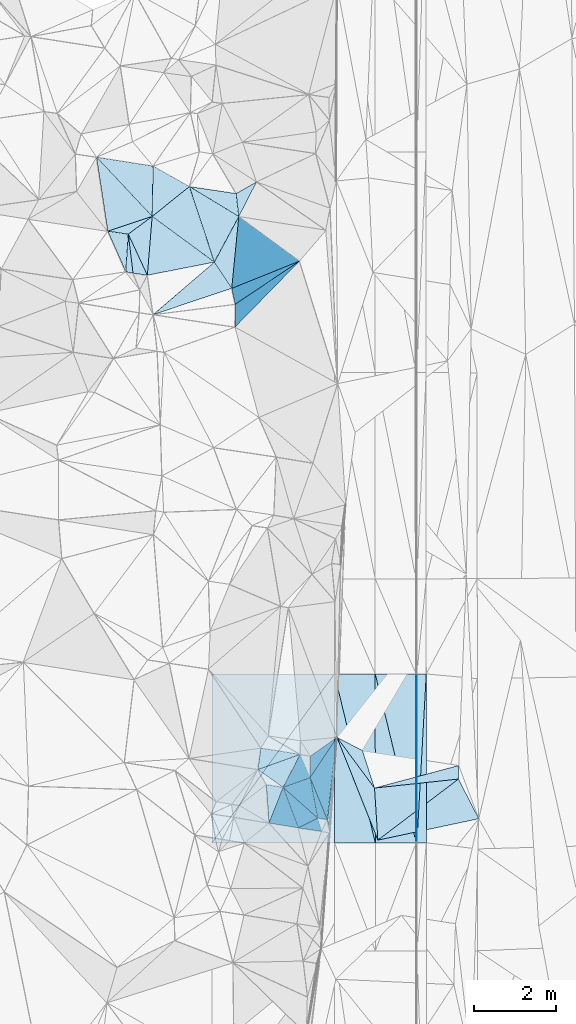
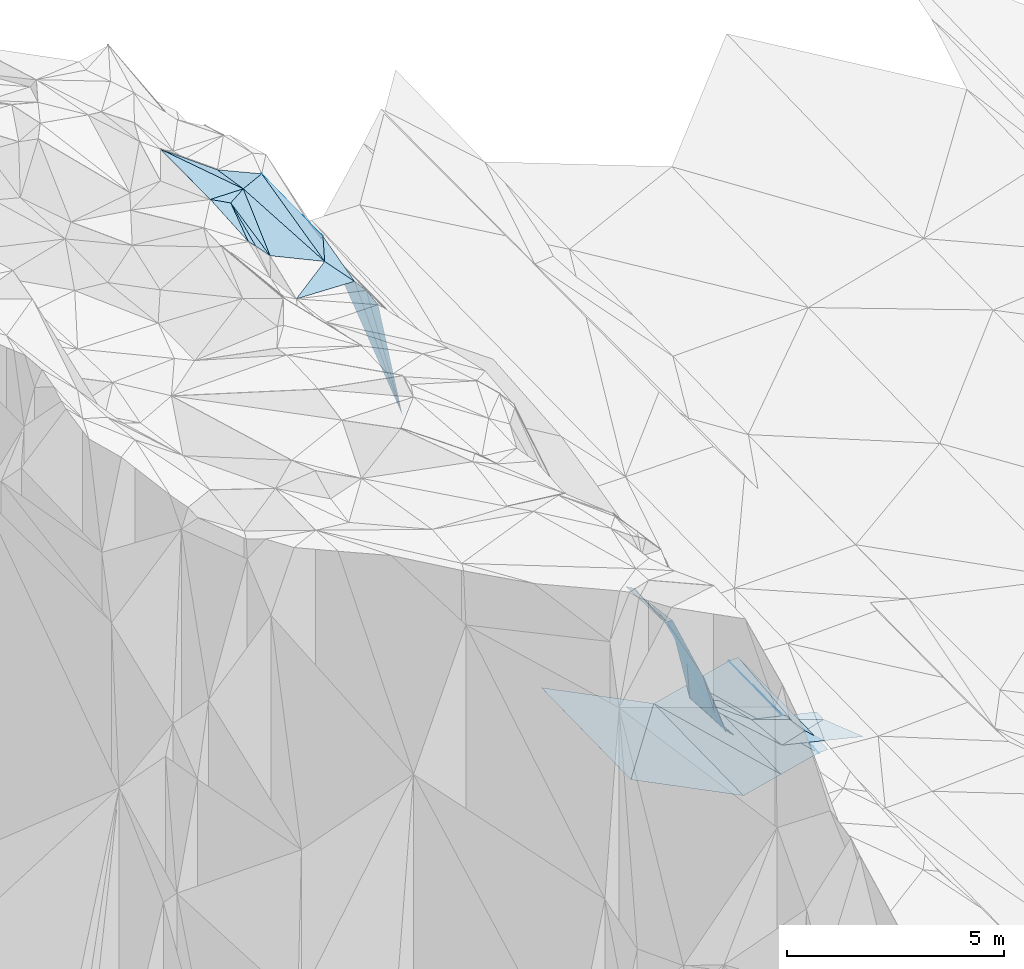
# One storey, part 137 of 275: 45 plates.
"""IFC2X3 building model written with IfcOpenShell, lengths in millimetres."""

from ifc_helpers import new_model, si_unit, frame, origin_with_axes, place, context, subcontext, project, spatial, polyline, outline, extrude, material, type_object, element, save


model = new_model("IFC2X3")

# Units and contexts
model_context = context("Model", 3, precision=1e-05, world=origin_with_axes())
body_context = subcontext(model_context, "Body", "Model", "MODEL_VIEW")
ifc_project = project(units=[si_unit("LENGTHUNIT", "METRE", prefix="MILLI"), si_unit("AREAUNIT", "SQUARE_METRE"), si_unit("VOLUMEUNIT", "CUBIC_METRE"), si_unit("MASSUNIT", "GRAM", prefix="KILO"), si_unit("TIMEUNIT", "SECOND"), si_unit("PLANEANGLEUNIT", "RADIAN"), si_unit("SOLIDANGLEUNIT", "STERADIAN"), si_unit("THERMODYNAMICTEMPERATUREUNIT", "DEGREE_CELSIUS"), si_unit("LUMINOUSINTENSITYUNIT", "LUMEN")], contexts=[model_context])

# Site, building, storey
site_placement = place(None, origin_with_axes())
site = spatial("IfcSite", under=ifc_project, at=site_placement, CompositionType="ELEMENT")
building_placement = place(site_placement, origin_with_axes())
building = spatial("IfcBuilding", under=site, at=building_placement, Name="Undefined", CompositionType="ELEMENT")
storey_placement = place(building_placement, origin_with_axes())
storey = spatial("IfcBuildingStorey", under=building, at=storey_placement, Name="Undefined", CompositionType="ELEMENT", Elevation=0.0)

# Plates
ifc_material = material()
plate_type_1 = type_object("IfcPlateType", PredefinedType="NOTDEFINED")
plate_1_placement = place(storey_placement, frame((-95657.7997569619, 119206.328885312, 43347.7477337184), z_axis=(0.0499189800945306, 0.0211429386415349, -0.998529454533977), x_axis=(0.998752315665235, 0.000325866070990781, 0.0499370179790064)))
element("IfcPlate", 1, at=plate_1_placement, inside=storey, type_object=plate_type_1, material=ifc_material, Name="00_PR", context=body_context, shape_type="SweptSolid", body=[
    extrude(outline(polyline([(0.0, 0.0), (20.0252170562744, 7.18500814400613e-11), (15.6301794052124, 4137.787109375), (0.0, 0.0)])), frame((-8.85201319254618e-08, 2.18876761149539e-07, -0.5000001331573), z_axis=(0.0, 0.0, 1.0), x_axis=(1.0, 0.0, 0.0)), (0.0, 0.0, 1.0), 1.0),
])
plate_2_placement = place(storey_placement, frame((-95636.4740437341, 115069.471827393, 43261.219733318), z_axis=(0.0499189800945306, 0.0211429386415349, -0.998529454533977), x_axis=(-0.998752315521962, -0.000325847078123489, -0.0499370209684242)))
element("IfcPlate", 2, at=plate_2_placement, inside=storey, type_object=plate_type_1, material=ifc_material, Name="00_PR", context=body_context, shape_type="SweptSolid", body=[
    extrude(outline(polyline([(0.0, 0.0), (20.0252170562744, 7.18500814400613e-11), (15.629919052124, 4137.787109375), (0.0, 0.0)])), frame((-8.85201319254618e-08, 2.18876761149539e-07, -0.5000001331573), z_axis=(0.0, 0.0, 1.0), x_axis=(1.0, 0.0, 0.0)), (0.0, 0.0, 1.0), 1.0),
])
plate_type_2 = type_object("IfcPlateType", PredefinedType="NOTDEFINED")
plate_3_placement = place(storey_placement, frame((-102099.905553327, 131648.352833847, 51889.5198908678), z_axis=(-0.224023126108306, -0.166971424768084, -0.960174037495067), x_axis=(0.864380306901367, -0.489129499428208, -0.116614826802635)))
element("IfcPlate", 3, at=plate_3_placement, inside=storey, type_object=plate_type_2, material=ifc_material, Name="00", context=body_context, shape_type="SweptSolid", body=[
    extrude(outline(polyline([(0.0, 0.0), (1029.02868652344, -1.05137587524951e-08), (558.585021972656, 1123.02392578125), (0.0, 0.0)])), frame((-8.85201319254618e-08, 2.18876761149539e-07, -0.5000001331573), z_axis=(0.0, 0.0, 1.0), x_axis=(1.0, 0.0, 0.0)), (0.0, 0.0, 1.0), 1.0),
])
plate_type_3 = type_object("IfcPlateType", PredefinedType="NOTDEFINED")
plate_4_placement = place(storey_placement, frame((-95636.4740437341, 115069.471827393, 43261.219733318), z_axis=(0.0499189800945306, 0.0211429386415349, -0.998529454533977), x_axis=(0.0551762169510029, 0.99819068915164, 0.0238942079582187)))
element("IfcPlate", 4, at=plate_4_placement, inside=storey, type_object=plate_type_3, material=ifc_material, Name="00_PR", context=body_context, shape_type="SweptSolid", body=[
    extrude(outline(polyline([(0.0, 0.0), (4144.435546875, -1.29366526380181e-08), (13.0387926101685, 229.918563842773), (0.0, 0.0)])), frame((-8.85201319254618e-08, 2.18876761149539e-07, -0.5000001331573), z_axis=(0.0, 0.0, 1.0), x_axis=(1.0, 0.0, 0.0)), (0.0, 0.0, 1.0), 1.0),
])
plate_5_placement = place(storey_placement, frame((-95407.799772619, 119206.40858086, 43360.2477330128), z_axis=(0.0499189800945306, 0.0211429386415349, -0.998529454533977), x_axis=(-0.0551762169455599, -0.998190689152155, -0.0238942079492684)))
element("IfcPlate", 5, at=plate_5_placement, inside=storey, type_object=plate_type_3, material=ifc_material, Name="00_PR", context=body_context, shape_type="SweptSolid", body=[
    extrude(outline(polyline([(0.0, 0.0), (4144.435546875, -1.29366526380181e-08), (13.0383386611938, 229.917678833008), (0.0, 0.0)])), frame((-8.85201319254618e-08, 2.18876761149539e-07, -0.5000001331573), z_axis=(0.0, 0.0, 1.0), x_axis=(1.0, 0.0, 0.0)), (0.0, 0.0, 1.0), 1.0),
])
plate_type_4 = type_object("IfcPlateType", PredefinedType="NOTDEFINED")
plate_6_placement = place(storey_placement, frame((-100656.721570657, 115067.86071912, 44260.2718656705), z_axis=(-0.447139607489667, 0.0187776393919987, -0.894267058362797), x_axis=(0.565598986891882, 0.780461813962238, -0.266415357991333)))
element("IfcPlate", 6, at=plate_6_placement, inside=storey, type_object=plate_type_4, material=ifc_material, Name="00_PR", context=body_context, shape_type="SweptSolid", body=[
    extrude(outline(polyline([(0.0, 0.0), (5301.7666015625, -1.97906047105789e-08), (2097.17041015625, 2617.60864257813), (0.0, 0.0)])), frame((-8.85201319254618e-08, 2.18876761149539e-07, -0.5000001331573), z_axis=(0.0, 0.0, 1.0), x_axis=(1.0, 0.0, 0.0)), (0.0, 0.0, 1.0), 1.0),
])
plate_7_placement = place(storey_placement, frame((-97658.0478488639, 119205.68696944, 42847.7998655597), z_axis=(-0.447139607489667, 0.0187776393919987, -0.894267058362797), x_axis=(-0.565598986896376, -0.780461813959011, 0.266415357991243)))
element("IfcPlate", 7, at=plate_7_placement, inside=storey, type_object=plate_type_4, material=ifc_material, Name="00_PR", context=body_context, shape_type="SweptSolid", body=[
    extrude(outline(polyline([(0.0, 0.0), (5301.7666015625, -1.97906047105789e-08), (2097.17114257813, 2617.60913085938), (0.0, 0.0)])), frame((-8.85201319254618e-08, 2.18876761149539e-07, -0.5000001331573), z_axis=(0.0, 0.0, 1.0), x_axis=(1.0, 0.0, 0.0)), (0.0, 0.0, 1.0), 1.0),
])
plate_type_5 = type_object("IfcPlateType", PredefinedType="NOTDEFINED")
plate_8_placement = place(storey_placement, frame((-95656.3779975561, 115069.465031929, 43260.2340293035), z_axis=(0.242478143133312, 0.0205997553447891, -0.969938142451546), x_axis=(-0.970142403271045, -0.000311047105442569, -0.242535813077531)))
element("IfcPlate", 8, at=plate_8_placement, inside=storey, type_object=plate_type_5, material=ifc_material, Name="00_PR", context=body_context, shape_type="SweptSolid", body=[
    extrude(outline(polyline([(0.0, 0.0), (1030.77563476563, 6.37373887002468e-09), (1009.54693603516, 4137.73486328125), (0.0, 0.0)])), frame((-8.85201319254618e-08, 2.18876761149539e-07, -0.5000001331573), z_axis=(0.0, 0.0, 1.0), x_axis=(1.0, 0.0, 0.0)), (0.0, 0.0, 1.0), 1.0),
])
plate_9_placement = place(storey_placement, frame((-97657.7030505073, 119205.687881482, 42847.7620287672), z_axis=(0.242478143133312, 0.0205997553447891, -0.969938142451546), x_axis=(0.970142426600282, 0.000310161083506448, 0.242535720895334)))
element("IfcPlate", 9, at=plate_9_placement, inside=storey, type_object=plate_type_5, material=ifc_material, Name="00_PR", context=body_context, shape_type="SweptSolid", body=[
    extrude(outline(polyline([(0.0, 0.0), (1030.77600097656, -5.77711034566164e-09), (1009.55102539063, 4137.73486328125), (0.0, 0.0)])), frame((-8.85201319254618e-08, 2.18876761149539e-07, -0.5000001331573), z_axis=(0.0, 0.0, 1.0), x_axis=(1.0, 0.0, 0.0)), (0.0, 0.0, 1.0), 1.0),
])
plate_10_placement = place(storey_placement, frame((-96656.3771238937, 115069.144410503, 43010.2340288523), z_axis=(0.242478143133312, 0.0205997553447891, -0.969938142451546), x_axis=(-0.970142403271045, -0.000311047105442569, -0.242535813077531)))
element("IfcPlate", 10, at=plate_10_placement, inside=storey, type_object=plate_type_5, material=ifc_material, Name="00_PR", context=body_context, shape_type="SweptSolid", body=[
    extrude(outline(polyline([(0.0, 0.0), (1030.77648925781, -5.90807758271694e-09), (1009.54577636719, 4137.736328125), (0.0, 0.0)])), frame((-8.85201319254618e-08, 2.18876761149539e-07, -0.5000001331573), z_axis=(0.0, 0.0, 1.0), x_axis=(1.0, 0.0, 0.0)), (0.0, 0.0, 1.0), 1.0),
])
plate_11_placement = place(storey_placement, frame((-95656.3779975561, 115069.465031929, 43260.2340293035), z_axis=(0.242478143133312, 0.0205997553447891, -0.969938142451546), x_axis=(-0.235101950998701, 0.971221851653558, -0.0381469200229675)))
element("IfcPlate", 11, at=plate_11_placement, inside=storey, type_object=plate_type_5, material=ifc_material, Name="00_PR", context=body_context, shape_type="SweptSolid", body=[
    extrude(outline(polyline([(0.0, 0.0), (4259.11181640625, 8.72387317940593e-09), (4014.78491210938, 1001.40130615234), (0.0, 0.0)])), frame((-8.85201319254618e-08, 2.18876761149539e-07, -0.5000001331573), z_axis=(0.0, 0.0, 1.0), x_axis=(1.0, 0.0, 0.0)), (0.0, 0.0, 1.0), 1.0),
])
plate_type_6 = type_object("IfcPlateType", PredefinedType="NOTDEFINED")
plate_12_placement = place(storey_placement, frame((-102122.773016315, 130414.07371194, 52109.64979854), z_axis=(-0.497174656538114, 0.512165067985138, -0.700360124530221), x_axis=(0.568197546549792, -0.41783970095931, -0.708915744215793)))
element("IfcPlate", 12, at=plate_12_placement, inside=storey, type_object=plate_type_6, material=ifc_material, Name="00", context=body_context, shape_type="SweptSolid", body=[
    extrude(outline(polyline([(0.0, 0.0), (2680.14916992188, 3.56521923094988e-10), (1222.76770019531, 1238.84582519531), (0.0, 0.0)])), frame((-8.85201319254618e-08, 2.18876761149539e-07, -0.5000001331573), z_axis=(0.0, 0.0, 1.0), x_axis=(1.0, 0.0, 0.0)), (0.0, 0.0, 1.0), 1.0),
])
plate_type_7 = type_object("IfcPlateType", PredefinedType="NOTDEFINED")
plate_13_placement = place(storey_placement, frame((-97831.4551601656, 115637.088812898, 44349.5587259273), z_axis=(-0.451830285709797, -0.130512359907913, -0.882505476938625), x_axis=(0.113969218789474, 0.972690123334175, -0.202200250090507)))
element("IfcPlate", 13, at=plate_13_placement, inside=storey, type_object=plate_type_7, material=ifc_material, Name="00", context=body_context, shape_type="SweptSolid", body=[
    extrude(outline(polyline([(0.0, 0.0), (2072.203125, 7.11588654667139e-09), (-305.346496582031, 98.3031616210938), (0.0, 0.0)])), frame((-8.85201319254618e-08, 2.18876761149539e-07, -0.5000001331573), z_axis=(0.0, 0.0, 1.0), x_axis=(1.0, 0.0, 0.0)), (0.0, 0.0, 1.0), 1.0),
])
plate_type_8 = type_object("IfcPlateType", PredefinedType="NOTDEFINED")
plate_14_placement = place(storey_placement, frame((-97595.1780241425, 117652.750470374, 43930.5138854005), z_axis=(-0.23225287574013, -0.0303195411463522, -0.972182764265606), x_axis=(0.591057918675384, -0.798199657822635, -0.116309255964225)))
element("IfcPlate", 14, at=plate_14_placement, inside=storey, type_object=plate_type_8, material=ifc_material, Name="00", context=body_context, shape_type="SweptSolid", body=[
    extrude(outline(polyline([(0.0, 0.0), (1556.19604492188, -7.86167220212519e-09), (2620.85620117188, 707.459228515625), (0.0, 0.0)])), frame((-8.85201319254618e-08, 2.18876761149539e-07, -0.5000001331573), z_axis=(0.0, 0.0, 1.0), x_axis=(1.0, 0.0, 0.0)), (0.0, 0.0, 1.0), 1.0),
])
plate_type_9 = type_object("IfcPlateType", PredefinedType="NOTDEFINED")
plate_15_placement = place(storey_placement, frame((-100093.564211617, 127702.935233351, 49779.845434467), z_axis=(-0.950183527757547, 0.0401883292773488, -0.309089245636463), x_axis=(0.007365590599984, 0.994271056205315, 0.106634023029618)))
element("IfcPlate", 15, at=plate_15_placement, inside=storey, type_object=plate_type_9, material=ifc_material, Name="00", context=body_context, shape_type="SweptSolid", body=[
    extrude(outline(polyline([(0.0, 0.0), (562.672180175781, 1.76078174263239e-09), (1123.92260742188, 5047.2666015625), (0.0, 0.0)])), frame((-8.85201319254618e-08, 2.18876761149539e-07, -0.5000001331573), z_axis=(0.0, 0.0, 1.0), x_axis=(1.0, 0.0, 0.0)), (0.0, 0.0, 1.0), 1.0),
])
plate_type_10 = type_object("IfcPlateType", PredefinedType="NOTDEFINED")
plate_16_placement = place(storey_placement, frame((-97831.6546970031, 115637.303435112, 44349.7839209817), z_axis=(-0.850902316742502, 0.298733182846329, -0.432115416097071), x_axis=(-0.432102771273474, 0.0697831419234681, 0.899120408043924)))
element("IfcPlate", 16, at=plate_16_placement, inside=storey, type_object=plate_type_10, material=ifc_material, Name="00", context=body_context, shape_type="SweptSolid", body=[
    extrude(outline(polyline([(0.0, 0.0), (544.97705078125, 2.44472175836563e-09), (1638.41760253906, 959.264221191406), (0.0, 0.0)])), frame((-8.85201319254618e-08, 2.18876761149539e-07, -0.5000001331573), z_axis=(0.0, 0.0, 1.0), x_axis=(1.0, 0.0, 0.0)), (0.0, 0.0, 1.0), 1.0),
])
plate_type_11 = type_object("IfcPlateType", PredefinedType="NOTDEFINED")
plate_17_placement = place(storey_placement, frame((-103486.4873794, 131866.494264686, 52819.5321483004), z_axis=(-0.312529891801399, 0.163905591871924, -0.935660207384989), x_axis=(0.644762798502136, -0.686738835943239, -0.335664571968833)))
element("IfcPlate", 17, at=plate_17_placement, inside=storey, type_object=plate_type_11, material=ifc_material, Name="00", context=body_context, shape_type="SweptSolid", body=[
    extrude(outline(polyline([(0.0, 0.0), (2115.20678710938, 1.58051989274099e-08), (1561.02941894531, 1046.22521972656), (0.0, 0.0)])), frame((-8.85201319254618e-08, 2.18876761149539e-07, -0.5000001331573), z_axis=(0.0, 0.0, 1.0), x_axis=(1.0, 0.0, 0.0)), (0.0, 0.0, 1.0), 1.0),
])
plate_type_12 = type_object("IfcPlateType", PredefinedType="NOTDEFINED")
plate_18_placement = place(storey_placement, frame((-102707.435644918, 129980.656036374, 52179.643074612), z_axis=(-0.470209948941076, 0.519019462738348, -0.713807678030734), x_axis=(0.79965170983787, 0.592782769361992, -0.0957378258626066)))
element("IfcPlate", 18, at=plate_18_placement, inside=storey, type_object=plate_type_12, material=ifc_material, Name="00", context=body_context, shape_type="SweptSolid", body=[
    extrude(outline(polyline([(0.0, 0.0), (731.163452148438, -3.28873284161091e-09), (-123.912101745605, 1516.16149902344), (0.0, 0.0)])), frame((-8.85201319254618e-08, 2.18876761149539e-07, -0.5000001331573), z_axis=(0.0, 0.0, 1.0), x_axis=(1.0, 0.0, 0.0)), (0.0, 0.0, 1.0), 1.0),
])
plate_type_13 = type_object("IfcPlateType", PredefinedType="NOTDEFINED")
plate_19_placement = place(storey_placement, frame((-98913.4692593187, 116427.175153325, 47269.7208708741), z_axis=(-0.829287975368046, -0.0260230301930222, -0.558215241470117), x_axis=(-0.526493796425237, 0.371211237003541, 0.764857176110705)))
element("IfcPlate", 19, at=plate_19_placement, inside=storey, type_object=plate_type_13, material=ifc_material, Name="00", context=body_context, shape_type="SweptSolid", body=[
    extrude(outline(polyline([(0.0, 0.0), (1176.69030761719, 1.57160684466362e-09), (-425.260589599609, 1041.03479003906), (0.0, 0.0)])), frame((-8.85201319254618e-08, 2.18876761149539e-07, -0.5000001331573), z_axis=(0.0, 0.0, 1.0), x_axis=(1.0, 0.0, 0.0)), (0.0, 0.0, 1.0), 1.0),
])
plate_type_14 = type_object("IfcPlateType", PredefinedType="NOTDEFINED")
plate_20_placement = place(storey_placement, frame((-98494.6107167275, 117235.66511686, 46609.7954849998), z_axis=(-0.902672441199311, 0.133834952923958, -0.408987370556988), x_axis=(0.254203628361098, -0.601024587056387, -0.757726838037133)))
element("IfcPlate", 20, at=plate_20_placement, inside=storey, type_object=plate_type_14, material=ifc_material, Name="00", context=body_context, shape_type="SweptSolid", body=[
    extrude(outline(polyline([(0.0, 0.0), (950.210510253906, 3.01224645227194e-09), (-120.710098266602, 1118.04699707031), (0.0, 0.0)])), frame((-8.85201319254618e-08, 2.18876761149539e-07, -0.5000001331573), z_axis=(0.0, 0.0, 1.0), x_axis=(1.0, 0.0, 0.0)), (0.0, 0.0, 1.0), 1.0),
])
plate_type_15 = type_object("IfcPlateType", PredefinedType="NOTDEFINED")
plate_21_placement = place(storey_placement, frame((-94612.197936517, 116961.972989749, 42909.5388645493), z_axis=(-0.38500089440911, 0.0357046754068877, -0.922225291053262), x_axis=(-0.0203554403304405, -0.999336819603452, -0.0301923340239145)))
element("IfcPlate", 21, at=plate_21_placement, inside=storey, type_object=plate_type_15, material=ifc_material, Name="00", context=body_context, shape_type="SweptSolid", body=[
    extrude(outline(polyline([(0.0, 0.0), (331.209899902344, -1.03318598121405e-09), (567.615905761719, 2223.603515625), (0.0, 0.0)])), frame((-8.85201319254618e-08, 2.18876761149539e-07, -0.5000001331573), z_axis=(0.0, 0.0, 1.0), x_axis=(1.0, 0.0, 0.0)), (0.0, 0.0, 1.0), 1.0),
])
plate_type_16 = type_object("IfcPlateType", PredefinedType="NOTDEFINED")
plate_22_placement = place(storey_placement, frame((-100173.709294752, 128651.466215929, 49889.5647474885), z_axis=(-0.478312203136888, 0.116244332397154, -0.870462343536971), x_axis=(-0.510538241557818, 0.769684527086152, 0.383322883051896)))
element("IfcPlate", 22, at=plate_22_placement, inside=storey, type_object=plate_type_16, material=ifc_material, Name="00", context=body_context, shape_type="SweptSolid", body=[
    extrude(outline(polyline([(0.0, 0.0), (834.805358886719, 5.07861841470003e-09), (1320.18798828125, 1185.41284179688), (0.0, 0.0)])), frame((-8.85201319254618e-08, 2.18876761149539e-07, -0.5000001331573), z_axis=(0.0, 0.0, 1.0), x_axis=(1.0, 0.0, 0.0)), (0.0, 0.0, 1.0), 1.0),
])
plate_type_17 = type_object("IfcPlateType", PredefinedType="NOTDEFINED")
plate_23_placement = place(storey_placement, frame((-100599.962487597, 129294.145550534, 50209.6474253526), z_axis=(-0.584575898372801, 0.401366547995445, -0.705107022509245), x_axis=(-0.568197546544758, 0.417839700962563, 0.70891574421791)))
element("IfcPlate", 23, at=plate_23_placement, inside=storey, type_object=plate_type_17, material=ifc_material, Name="00", context=body_context, shape_type="SweptSolid", body=[
    extrude(outline(polyline([(0.0, 0.0), (2680.14916992188, 3.56521923094988e-10), (2226.36865234375, 1129.85974121094), (0.0, 0.0)])), frame((-8.85201319254618e-08, 2.18876761149539e-07, -0.5000001331573), z_axis=(0.0, 0.0, 1.0), x_axis=(1.0, 0.0, 0.0)), (0.0, 0.0, 1.0), 1.0),
])
plate_type_18 = type_object("IfcPlateType", PredefinedType="NOTDEFINED")
plate_24_placement = place(storey_placement, frame((-99259.3952334146, 115552.593134841, 47959.7332315974), z_axis=(-0.841193881947169, -0.0881880793607203, -0.533493875909855), x_axis=(-0.0709444092881648, 0.996082236952213, -0.0527926890679893)))
element("IfcPlate", 24, at=plate_24_placement, inside=storey, type_object=plate_type_18, material=ifc_material, Name="00", context=body_context, shape_type="SweptSolid", body=[
    extrude(outline(polyline([(0.0, 0.0), (947.100830078125, -1.94995664060116e-09), (883.010498046875, 762.163024902344), (0.0, 0.0)])), frame((-8.85201319254618e-08, 2.18876761149539e-07, -0.5000001331573), z_axis=(0.0, 0.0, 1.0), x_axis=(1.0, 0.0, 0.0)), (0.0, 0.0, 1.0), 1.0),
])
plate_type_19 = type_object("IfcPlateType", PredefinedType="NOTDEFINED")
plate_25_placement = place(storey_placement, frame((-98067.1897690882, 115675.192186388, 44839.8423138794), z_axis=(-0.948850455989885, 0.015814392545555, -0.315329537398898), x_axis=(0.215299425244365, -0.698100128642918, -0.682863359595598)))
element("IfcPlate", 25, at=plate_25_placement, inside=storey, type_object=plate_type_19, material=ifc_material, Name="00", context=body_context, shape_type="SweptSolid", body=[
    extrude(outline(polyline([(0.0, 0.0), (468.614990234375, -1.94995664060116e-09), (-895.831359863281, 1211.35717773438), (0.0, 0.0)])), frame((-8.85201319254618e-08, 2.18876761149539e-07, -0.5000001331573), z_axis=(0.0, 0.0, 1.0), x_axis=(1.0, 0.0, 0.0)), (0.0, 0.0, 1.0), 1.0),
])
plate_type_20 = type_object("IfcPlateType", PredefinedType="NOTDEFINED")
plate_26_placement = place(storey_placement, frame((-100089.407419819, 128262.285455883, 49839.8274657768), z_axis=(-0.925417124859326, -0.156717350878885, -0.345025820701297), x_axis=(-0.210656298388397, 0.969585464796822, 0.124611196944851)))
element("IfcPlate", 26, at=plate_26_placement, inside=storey, type_object=plate_type_20, material=ifc_material, Name="00", context=body_context, shape_type="SweptSolid", body=[
    extrude(outline(polyline([(0.0, 0.0), (401.248046875, -9.53150447458029e-10), (106.667182922363, 5077.25537109375), (0.0, 0.0)])), frame((-8.85201319254618e-08, 2.18876761149539e-07, -0.5000001331573), z_axis=(0.0, 0.0, 1.0), x_axis=(1.0, 0.0, 0.0)), (0.0, 0.0, 1.0), 1.0),
])
plate_type_21 = type_object("IfcPlateType", PredefinedType="NOTDEFINED")
plate_27_placement = place(storey_placement, frame((-98253.0895339432, 116664.523585375, 45889.8525770876), z_axis=(-0.954221478392425, 0.0505223783531757, -0.294803085906699), x_axis=(0.287068113002737, 0.431449764966625, -0.855244408813815)))
element("IfcPlate", 27, at=plate_27_placement, inside=storey, type_object=plate_type_21, material=ifc_material, Name="00", context=body_context, shape_type="SweptSolid", body=[
    extrude(outline(polyline([(0.0, 0.0), (2290.5732421875, -8.14907252788544e-09), (994.794616699219, 1617.09106445313), (0.0, 0.0)])), frame((-8.85201319254618e-08, 2.18876761149539e-07, -0.5000001331573), z_axis=(0.0, 0.0, 1.0), x_axis=(1.0, 0.0, 0.0)), (0.0, 0.0, 1.0), 1.0),
])
plate_type_22 = type_object("IfcPlateType", PredefinedType="NOTDEFINED")
plate_28_placement = place(storey_placement, frame((-100000.873342364, 130411.668123434, 50029.732629754), z_axis=(-0.844584666466867, -0.0278403544883989, -0.534697723794493), x_axis=(-0.110200017415241, 0.986305006885064, 0.122712629973996)))
element("IfcPlate", 28, at=plate_28_placement, inside=storey, type_object=plate_type_22, material=ifc_material, Name="00", context=body_context, shape_type="SweptSolid", body=[
    extrude(outline(polyline([(0.0, 0.0), (570.438415527344, -1.30967237055302e-10), (698.936096191406, 975.698913574219), (0.0, 0.0)])), frame((-8.85201319254618e-08, 2.18876761149539e-07, -0.5000001331573), z_axis=(0.0, 0.0, 1.0), x_axis=(1.0, 0.0, 0.0)), (0.0, 0.0, 1.0), 1.0),
])
plate_type_23 = type_object("IfcPlateType", PredefinedType="NOTDEFINED")
plate_29_placement = place(storey_placement, frame((-103486.614361257, 131866.345095708, 52819.5934575584), z_axis=(-0.566471244780148, -0.134448307057021, -0.813039963080986), x_axis=(0.823498425982698, -0.129461251601275, -0.552349641746829)))
element("IfcPlate", 29, at=plate_29_placement, inside=storey, type_object=plate_type_23, material=ifc_material, Name="00", context=body_context, shape_type="SweptSolid", body=[
    extrude(outline(polyline([(0.0, 0.0), (1683.71618652344, 1.0433723218739e-08), (1703.31567382813, 1254.11950683594), (0.0, 0.0)])), frame((-8.85201319254618e-08, 2.18876761149539e-07, -0.5000001331573), z_axis=(0.0, 0.0, 1.0), x_axis=(1.0, 0.0, 0.0)), (0.0, 0.0, 1.0), 1.0),
])
plate_type_24 = type_object("IfcPlateType", PredefinedType="NOTDEFINED")
plate_30_placement = place(storey_placement, frame((-97595.1440411186, 117652.776693961, 43930.5068918904), z_axis=(-0.164190662747372, 0.0221194532371122, -0.986180589980897), x_axis=(0.876512956386765, -0.455350109570503, -0.156145172836896)))
element("IfcPlate", 30, at=plate_30_placement, inside=storey, type_object=plate_type_24, material=ifc_material, Name="00", context=body_context, shape_type="SweptSolid", body=[
    extrude(outline(polyline([(0.0, 0.0), (710.876953125, 3.34694050252438e-09), (1400.09606933594, 679.320922851563), (0.0, 0.0)])), frame((-8.85201319254618e-08, 2.18876761149539e-07, -0.5000001331573), z_axis=(0.0, 0.0, 1.0), x_axis=(1.0, 0.0, 0.0)), (0.0, 0.0, 1.0), 1.0),
])
plate_type_25 = type_object("IfcPlateType", PredefinedType="NOTDEFINED")
plate_31_placement = place(storey_placement, frame((-102769.073893329, 129056.788652247, 51669.5879630576), z_axis=(-0.308049937598355, 0.475477847054419, -0.824030371349348), x_axis=(-0.334533593322047, 0.75670005069124, 0.561687019809889)))
element("IfcPlate", 31, at=plate_31_placement, inside=storey, type_object=plate_type_25, material=ifc_material, Name="00", context=body_context, shape_type="SweptSolid", body=[
    extrude(outline(polyline([(0.0, 0.0), (1317.45971679688, 4.07453626394272e-09), (964.88720703125, 431.732147216797), (0.0, 0.0)])), frame((-8.85201319254618e-08, 2.18876761149539e-07, -0.5000001331573), z_axis=(0.0, 0.0, 1.0), x_axis=(1.0, 0.0, 0.0)), (0.0, 0.0, 1.0), 1.0),
])
plate_type_26 = type_object("IfcPlateType", PredefinedType="NOTDEFINED")
plate_32_placement = place(storey_placement, frame((-100599.842739785, 129294.057329858, 50209.5443649821), z_axis=(-0.345069166434611, 0.224927488762203, -0.911227136983558), x_axis=(0.510538241567749, -0.769684527078473, -0.383322883054088)))
element("IfcPlate", 32, at=plate_32_placement, inside=storey, type_object=plate_type_26, material=ifc_material, Name="00", context=body_context, shape_type="SweptSolid", body=[
    extrude(outline(polyline([(0.0, 0.0), (834.805358886719, 5.07861841470003e-09), (128.772537231445, 1985.67810058594), (0.0, 0.0)])), frame((-8.85201319254618e-08, 2.18876761149539e-07, -0.5000001331573), z_axis=(0.0, 0.0, 1.0), x_axis=(1.0, 0.0, 0.0)), (0.0, 0.0, 1.0), 1.0),
])
plate_type_27 = type_object("IfcPlateType", PredefinedType="NOTDEFINED")
plate_33_placement = place(storey_placement, frame((-98913.5140699576, 116427.215820161, 47269.8046911317), z_axis=(-0.918908081822054, 0.0553108016846693, -0.39057477181599), x_axis=(0.253843362296866, -0.67497088186585, -0.69280434182463)))
element("IfcPlate", 33, at=plate_33_placement, inside=storey, type_object=plate_type_27, material=ifc_material, Name="00", context=body_context, shape_type="SweptSolid", body=[
    extrude(outline(polyline([(0.0, 0.0), (1472.27709960938, 1.07320374809206e-09), (24.4519176483154, 1166.19128417969), (0.0, 0.0)])), frame((-8.85201319254618e-08, 2.18876761149539e-07, -0.5000001331573), z_axis=(0.0, 0.0, 1.0), x_axis=(1.0, 0.0, 0.0)), (0.0, 0.0, 1.0), 1.0),
])
plate_type_28 = type_object("IfcPlateType", PredefinedType="NOTDEFINED")
plate_34_placement = place(storey_placement, frame((-101210.733993732, 131145.097055336, 51769.7177332867), z_axis=(-0.825147230422893, -0.0219618705617742, -0.564490676953), x_axis=(0.564153110141841, -0.0840074237730537, -0.821385427840245)))
element("IfcPlate", 34, at=plate_34_placement, inside=storey, type_object=plate_type_28, material=ifc_material, Name="00", context=body_context, shape_type="SweptSolid", body=[
    extrude(outline(polyline([(0.0, 0.0), (2033.15026855469, -6.97036739438772e-09), (2173.3759765625, 552.934692382813), (0.0, 0.0)])), frame((-8.85201319254618e-08, 2.18876761149539e-07, -0.5000001331573), z_axis=(0.0, 0.0, 1.0), x_axis=(1.0, 0.0, 0.0)), (0.0, 0.0, 1.0), 1.0),
])
plate_type_29 = type_object("IfcPlateType", PredefinedType="NOTDEFINED")
plate_35_placement = place(storey_placement, frame((-98253.0909470929, 116664.543886621, 45889.8623461328), z_axis=(-0.957039735561459, 0.0911271684825818, -0.275264933692615), x_axis=(0.0129869646688973, 0.961849747383823, 0.273269834058508)))
element("IfcPlate", 35, at=plate_35_placement, inside=storey, type_object=plate_type_29, material=ifc_material, Name="00", context=body_context, shape_type="SweptSolid", body=[
    extrude(outline(polyline([(0.0, 0.0), (548.908020019531, 1.42608769237995e-09), (423.768646240234, 2251.0322265625), (0.0, 0.0)])), frame((-8.85201319254618e-08, 2.18876761149539e-07, -0.5000001331573), z_axis=(0.0, 0.0, 1.0), x_axis=(1.0, 0.0, 0.0)), (0.0, 0.0, 1.0), 1.0),
])
plate_type_30 = type_object("IfcPlateType", PredefinedType="NOTDEFINED")
plate_36_placement = place(storey_placement, frame((-102591.58850659, 129025.952047821, 51499.6545969339), z_axis=(-0.588152148296852, 0.42062195108192, -0.690763508533736), x_axis=(-0.716837911199355, 0.12433571771956, 0.68606416490479)))
element("IfcPlate", 36, at=plate_36_placement, inside=storey, type_object=plate_type_30, material=ifc_material, Name="00", context=body_context, shape_type="SweptSolid", body=[
    extrude(outline(polyline([(0.0, 0.0), (247.790237426758, -5.67524693906307e-10), (668.307189941406, 969.827575683594), (0.0, 0.0)])), frame((-8.85201319254618e-08, 2.18876761149539e-07, -0.5000001331573), z_axis=(0.0, 0.0, 1.0), x_axis=(1.0, 0.0, 0.0)), (0.0, 0.0, 1.0), 1.0),
])
plate_type_31 = type_object("IfcPlateType", PredefinedType="NOTDEFINED")
plate_37_placement = place(storey_placement, frame((-98913.5000678602, 116427.308721874, 47269.8075246354), z_axis=(-0.890904476790846, 0.241112874462622, -0.384907514868703), x_axis=(0.426589196114378, 0.153282076070228, -0.891362026852216)))
element("IfcPlate", 37, at=plate_37_placement, inside=storey, type_object=plate_type_31, material=ifc_material, Name="00", context=body_context, shape_type="SweptSolid", body=[
    extrude(outline(polyline([(0.0, 0.0), (1548.19250488281, -7.42147676646709e-10), (2411.7802734375, 1170.47692871094), (0.0, 0.0)])), frame((-8.85201319254618e-08, 2.18876761149539e-07, -0.5000001331573), z_axis=(0.0, 0.0, 1.0), x_axis=(1.0, 0.0, 0.0)), (0.0, 0.0, 1.0), 1.0),
])
plate_type_32 = type_object("IfcPlateType", PredefinedType="NOTDEFINED")
plate_38_placement = place(storey_placement, frame((-101210.683966145, 131145.252026254, 51769.6871999872), z_axis=(-0.725084250034605, 0.287978389472702, -0.625556774040905), x_axis=(0.539492076049286, -0.327041243633924, -0.775881643578715)))
element("IfcPlate", 38, at=plate_38_placement, inside=storey, type_object=plate_type_32, material=ifc_material, Name="00", context=body_context, shape_type="SweptSolid", body=[
    extrude(outline(polyline([(0.0, 0.0), (2242.61010742188, -6.51925802230835e-09), (2145.2236328125, 1277.22973632813), (0.0, 0.0)])), frame((-8.85201319254618e-08, 2.18876761149539e-07, -0.5000001331573), z_axis=(0.0, 0.0, 1.0), x_axis=(1.0, 0.0, 0.0)), (0.0, 0.0, 1.0), 1.0),
])
plate_type_33 = type_object("IfcPlateType", PredefinedType="NOTDEFINED")
plate_39_placement = place(storey_placement, frame((-98913.5278640982, 116427.175270647, 47269.8391416447), z_axis=(-0.946499302049263, -0.0257870205177551, -0.32167390443285), x_axis=(0.315703745165681, -0.280514506862469, -0.906445120637796)))
element("IfcPlate", 39, at=plate_39_placement, inside=storey, type_object=plate_type_33, material=ifc_material, Name="00", context=body_context, shape_type="SweptSolid", body=[
    extrude(outline(polyline([(0.0, 0.0), (2680.80200195313, -4.30736690759659e-09), (1321.32092285156, 649.392761230469), (0.0, 0.0)])), frame((-8.85201319254618e-08, 2.18876761149539e-07, -0.5000001331573), z_axis=(0.0, 0.0, 1.0), x_axis=(1.0, 0.0, 0.0)), (0.0, 0.0, 1.0), 1.0),
])
plate_type_34 = type_object("IfcPlateType", PredefinedType="NOTDEFINED")
plate_40_placement = place(storey_placement, frame((-99532.970303824, 116863.885607118, 48169.7120884323), z_axis=(-0.791118635705161, -0.206418646632876, -0.575780033139616), x_axis=(0.122709764867523, 0.868637643102105, -0.480011415064452)))
element("IfcPlate", 40, at=plate_40_placement, inside=storey, type_object=plate_type_34, material=ifc_material, Name="00", context=body_context, shape_type="SweptSolid", body=[
    extrude(outline(polyline([(0.0, 0.0), (604.152282714844, 5.82076609134674e-10), (1199.03540039063, 1487.38500976563), (0.0, 0.0)])), frame((-8.85201319254618e-08, 2.18876761149539e-07, -0.5000001331573), z_axis=(0.0, 0.0, 1.0), x_axis=(1.0, 0.0, 0.0)), (0.0, 0.0, 1.0), 1.0),
])
plate_type_35 = type_object("IfcPlateType", PredefinedType="NOTDEFINED")
plate_41_placement = place(storey_placement, frame((-94618.9144384067, 116630.912922732, 42899.5315922722), z_axis=(-0.334160120913615, -0.103923644671107, -0.936769389801605), x_axis=(0.45550921679667, -0.887928871095105, -0.0639818199886208)))
element("IfcPlate", 41, at=plate_41_placement, inside=storey, type_object=plate_type_35, material=ifc_material, Name="00", context=body_context, shape_type="SweptSolid", body=[
    extrude(outline(polyline([(0.0, 0.0), (1094.06079101563, 4.63478500023484e-09), (373.443603515625, 2598.16088867188), (0.0, 0.0)])), frame((-8.85201319254618e-08, 2.18876761149539e-07, -0.5000001331573), z_axis=(0.0, 0.0, 1.0), x_axis=(1.0, 0.0, 0.0)), (0.0, 0.0, 1.0), 1.0),
])
plate_type_36 = type_object("IfcPlateType", PredefinedType="NOTDEFINED")
plate_42_placement = place(storey_placement, frame((-102240.399995254, 128973.469748436, 51139.6654363556), z_axis=(-0.625984957885527, 0.40058632642645, -0.669084021316618), x_axis=(-0.694541711122579, 0.103768271721002, 0.711929741824962)))
element("IfcPlate", 42, at=plate_42_placement, inside=storey, type_object=plate_type_36, material=ifc_material, Name="00", context=body_context, shape_type="SweptSolid", body=[
    extrude(outline(polyline([(0.0, 0.0), (505.667877197266, -1.13504938781261e-09), (1169.34460449219, 973.002136230469), (0.0, 0.0)])), frame((-8.85201319254618e-08, 2.18876761149539e-07, -0.5000001331573), z_axis=(0.0, 0.0, 1.0), x_axis=(1.0, 0.0, 0.0)), (0.0, 0.0, 1.0), 1.0),
])
plate_type_37 = type_object("IfcPlateType", PredefinedType="NOTDEFINED")
plate_43_placement = place(storey_placement, frame((-100000.922359689, 130411.74079434, 50029.8437309331), z_axis=(-0.942623262608814, 0.117505174730971, -0.312496269897994), x_axis=(0.284256919238114, -0.208434173878247, -0.935816861904587)))
element("IfcPlate", 43, at=plate_43_placement, inside=storey, type_object=plate_type_37, material=ifc_material, Name="00", context=body_context, shape_type="SweptSolid", body=[
    extrude(outline(polyline([(0.0, 0.0), (5236.0673828125, 1.75205059349537e-08), (448.733734130859, 1716.60656738281), (0.0, 0.0)])), frame((-8.85201319254618e-08, 2.18876761149539e-07, -0.5000001331573), z_axis=(0.0, 0.0, 1.0), x_axis=(1.0, 0.0, 0.0)), (0.0, 0.0, 1.0), 1.0),
])
plate_type_38 = type_object("IfcPlateType", PredefinedType="NOTDEFINED")
plate_44_placement = place(storey_placement, frame((-103209.830328314, 130053.63942229, 52409.5626541401), z_axis=(-0.351881423130529, 0.333419951414699, -0.874648843853494), x_axis=(0.918235178070007, 0.304362300413262, -0.253392477871561)))
element("IfcPlate", 44, at=plate_44_placement, inside=storey, type_object=plate_type_38, material=ifc_material, Name="00", context=body_context, shape_type="SweptSolid", body=[
    extrude(outline(polyline([(0.0, 0.0), (1183.93408203125, -3.46335582435131e-09), (497.409423828125, 251.56282043457), (0.0, 0.0)])), frame((-8.85201319254618e-08, 2.18876761149539e-07, -0.5000001331573), z_axis=(0.0, 0.0, 1.0), x_axis=(1.0, 0.0, 0.0)), (0.0, 0.0, 1.0), 1.0),
])
plate_type_39 = type_object("IfcPlateType", PredefinedType="NOTDEFINED")
plate_45_placement = place(storey_placement, frame((-96592.663817934, 115135.151217747, 43769.5375087351), z_axis=(-0.378111845221965, -0.0390459627412992, -0.924936130387632), x_axis=(-0.0647629306226039, 0.99777801377967, -0.0156460229793043)))
element("IfcPlate", 45, at=plate_45_placement, inside=storey, type_object=plate_type_39, material=ifc_material, Name="00", context=body_context, shape_type="SweptSolid", body=[
    extrude(outline(polyline([(0.0, 0.0), (1278.28015136719, 1.89174897968769e-09), (1378.25817871094, 2233.89892578125), (0.0, 0.0)])), frame((-8.85201319254618e-08, 2.18876761149539e-07, -0.5000001331573), z_axis=(0.0, 0.0, 1.0), x_axis=(1.0, 0.0, 0.0)), (0.0, 0.0, 1.0), 1.0),
])

save(model, "model.ifc")
